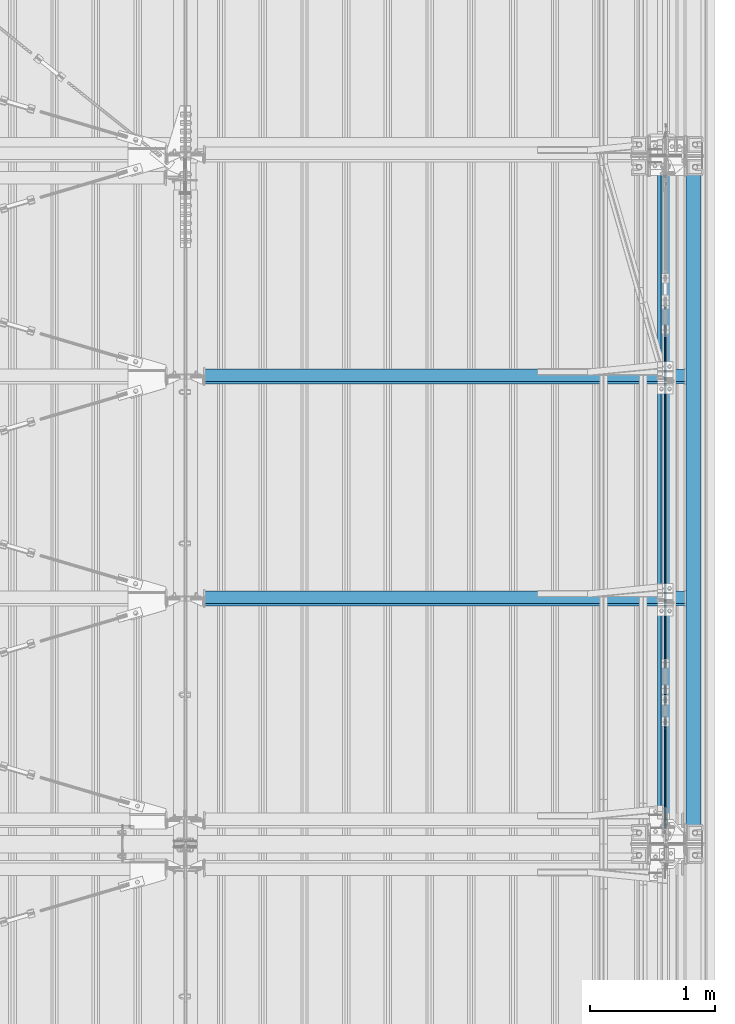
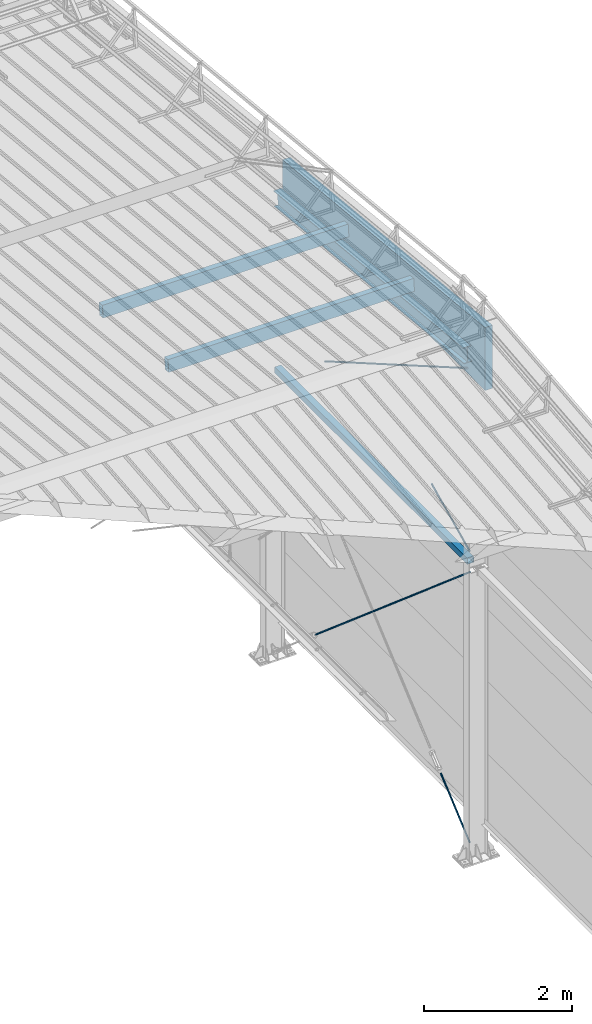
# One storey, part 283 of 709: 5 beams, 4 members, 4 openings, 9 elements without a shape of their own.
"""IFC4 building model written with IfcOpenShell, lengths in millimetres."""

from ifc_helpers import new_model, si_unit, direction, frame, origin_with_axes, place, context, subcontext, project, spatial, line, indexed_curve, outline, extrude, polygons, material, element, aggregate, save


model = new_model("IFC4")

# Units and contexts
model_context = context("Model", 3, precision=0.2, world=origin_with_axes(), true_north=direction((0.0, 1.0)))
body_context = subcontext(model_context, "Body", "Model", "MODEL_VIEW")
reference_context = subcontext(model_context, "Reference", "Model", "MODEL_VIEW")
ifc_project = project(units=[si_unit("LENGTHUNIT", "METRE", prefix="MILLI"), si_unit("AREAUNIT", "SQUARE_METRE"), si_unit("VOLUMEUNIT", "CUBIC_METRE"), si_unit("MASSUNIT", "GRAM", prefix="KILO"), si_unit("TIMEUNIT", "SECOND"), si_unit("PLANEANGLEUNIT", "RADIAN"), si_unit("SOLIDANGLEUNIT", "STERADIAN"), si_unit("THERMODYNAMICTEMPERATUREUNIT", "DEGREE_CELSIUS"), si_unit("LUMINOUSINTENSITYUNIT", "LUMEN")], contexts=[model_context])

# Site, building, storey
site_placement = place(None, origin_with_axes())
site = spatial("IfcSite", under=ifc_project, at=site_placement, CompositionType="ELEMENT")
building_placement = place(site_placement, origin_with_axes())
building = spatial("IfcBuilding", under=site, at=building_placement, Name="Undefined", CompositionType="ELEMENT")
storey_placement = place(building_placement, origin_with_axes())
storey = spatial("IfcBuildingStorey", under=building, at=storey_placement, Name="Undefined", CompositionType="ELEMENT", Elevation=0.0)

# Assembly, beam
assembly_1_placement = place(storey_placement, frame((49837.5, 16500.0, 7445.307), z_axis=(-1.0, 0.0, 0.0), x_axis=(0.0, -0.9950371902, 0.099503719)))
assembly_1 = element("IfcElementAssembly", 1, at=assembly_1_placement, inside=storey)
ifc_material_1 = material(Name="C255-4", Category="STEEL")
beam_1_placement = place(assembly_1_placement, origin_with_axes())
beam_1 = element("IfcBeam", 2, at=beam_1_placement, material=ifc_material_1, ObjectType="452", context=body_context, shape_type="Tessellation", body=[
    polygons([(166.87157, -124.0, 62.0), (166.87157, -116.0, 62.0), (166.87157, -116.0, 2.5), (166.87157, 116.0, 2.5), (166.87157, 116.0, 62.0), (166.87157, 124.0, 62.0), (166.87157, 124.0, -62.0), (166.87157, 116.0, -62.0), (166.87157, 116.0, -2.5), (166.87157, -116.0, -2.5), (166.87157, -116.0, -62.0), (166.87157, -124.0, -62.0), (5323.56002, 124.0, 62.0), (5323.56002, 124.0, -62.0), (5323.56002, 116.0, -62.0), (5323.56002, 116.0, -2.5), (5323.56002, -116.0, -2.5), (5323.56002, -116.0, -62.0), (5323.56002, -124.0, -62.0), (5323.56002, -124.0, 62.0), (5323.56002, -116.0, 62.0), (5323.56002, -116.0, 2.5), (5323.56002, 116.0, 2.5), (5323.56002, 116.0, 62.0)], [[[1, 2, 3, 4, 5, 6, 7, 8, 9, 10, 11, 12]], [[7, 6, 13, 14]], [[8, 7, 14, 15]], [[9, 8, 15, 16]], [[10, 9, 16, 17]], [[11, 10, 17, 18]], [[12, 11, 18, 19]], [[1, 12, 19, 20]], [[2, 1, 20, 21]], [[3, 2, 21, 22]], [[4, 3, 22, 23]], [[5, 4, 23, 24]], [[6, 5, 24, 13]], [[23, 22, 21, 20, 19, 18, 17, 16, 15, 14, 13, 24]]], closed=True),
])
aggregate(assembly_1, [beam_1])

assembly_2_placement = place(storey_placement, frame((49851.0, 11000.0, 4610.0), z_axis=(0.0, 0.0, -1.0), x_axis=(0.0, 1.0, 0.0)))
assembly_2 = element("IfcElementAssembly", 3, at=assembly_2_placement, inside=storey)
ifc_material_2 = material(Name="C355", Category="STEEL")
beam_2_placement = place(assembly_2_placement, origin_with_axes())
beam_2 = element("IfcBeam", 4, at=beam_2_placement, material=ifc_material_2, ObjectType="512", context=body_context, shape_type="Tessellation", body=[
    polygons([(142.5, -47.0, -47.0), (142.5, -47.0, 47.0), (5357.5, -47.0, 47.0), (5357.5, -47.0, -47.0), (142.5, 47.0, 47.0), (5357.5, 47.0, 47.0), (142.5, 47.0, -47.0), (5357.5, 47.0, -47.0), (142.5, -50.0, -50.0), (142.5, 50.0, -50.0), (5357.5, 50.0, -50.0), (5357.5, -50.0, -50.0), (142.5, 50.0, 50.0), (5357.5, 50.0, 50.0), (142.5, -50.0, 50.0), (5357.5, -50.0, 50.0)], [[[1, 2, 3, 4]], [[2, 5, 6, 3]], [[5, 7, 8, 6]], [[7, 1, 4, 8]], [[9, 10, 11, 12]], [[10, 13, 14, 11]], [[13, 15, 16, 14]], [[15, 9, 12, 16]], [[14, 16, 12, 11], [6, 8, 4, 3]], [[15, 13, 10, 9], [7, 5, 2, 1]]], closed=True),
])
aggregate(assembly_2, [beam_2])

# Assembly, member, voiding feature
assembly_3_placement = place(storey_placement, frame((49835.0, 11000.0, -155.0), z_axis=(1.0, 0.0, 0.0), x_axis=(0.0, 0.7603239329, 0.649544084)))
assembly_3 = element("IfcElementAssembly", 5, at=assembly_3_placement, inside=storey)
ifc_material_3 = material(Name="C355-5", Category="STEEL")
member_1_placement = place(assembly_3_placement, origin_with_axes())
member_1 = element("IfcMember", 6, at=member_1_placement, material=ifc_material_3, ObjectType="513", context=body_context, shape_type="Tessellation", body=[
    polygons([(1390.0, 7.36122, 4.25), (1390.0, 6.01041, 6.01041), (1390.0, 4.25, 7.36122), (1390.0, 2.19996, 8.21037), (1390.0, 0.0, 8.5), (1390.0, -2.19996, 8.21037), (1390.0, -4.25, 7.36122), (1390.0, -6.01041, 6.01041), (1390.0, -7.36122, 4.25), (1390.0, -8.21037, 2.19996), (1390.0, -8.5, 0.0), (1390.0, -8.21037, -2.19996), (1390.0, -7.36122, -4.25), (1390.0, -6.01041, -6.01041), (1390.0, -4.25, -7.36122), (1390.0, -2.19996, -8.21037), (1390.0, 0.0, -8.5), (1390.0, 2.19996, -8.21037), (1390.0, 4.25, -7.36122), (1390.0, 6.01041, -6.01041), (1390.0, 7.36122, -4.25), (1390.0, 8.21037, -2.19996), (1390.0, 8.5, 0.0), (1390.0, 8.21037, 2.19996), (1210.0, 8.21037, 2.19996), (1210.0, 7.36122, 4.25), (1210.0, 6.01041, 6.01041), (1210.0, 4.25, 7.36122), (1210.0, 2.19996, 8.21037), (1210.0, 0.0, 8.5), (1210.0, -2.19996, 8.21037), (1210.0, -4.25, 7.36122), (1210.0, -6.01041, 6.01041), (1210.0, -7.36122, 4.25), (1210.0, -8.21037, 2.19996), (1210.0, -8.5, 0.0), (1210.0, -8.21037, -2.19996), (1210.0, -7.36122, -4.25), (1210.0, -6.01041, -6.01041), (1210.0, -4.25, -7.36122), (1210.0, -2.19996, -8.21037), (1210.0, 0.0, -8.5), (1210.0, 2.19996, -8.21037), (1210.0, 4.25, -7.36122), (1210.0, 6.01041, -6.01041), (1210.0, 7.36122, -4.25), (1210.0, 8.21037, -2.19996), (1210.0, 8.5, 0.0), (1210.0, 10.0, 0.0), (1210.0, 9.65926, 2.58819), (1210.0, 8.66025, 5.0), (1210.0, 7.07107, 7.07107), (1210.0, 5.0, 8.66025), (1210.0, 2.58819, 9.65926), (1210.0, 0.0, 10.0), (1210.0, -2.58819, 9.65926), (1210.0, -5.0, 8.66025), (1210.0, -7.07107, 7.07107), (1210.0, -8.66025, 5.0), (1210.0, -9.65926, 2.58819), (1210.0, -10.0, 0.0), (1210.0, -9.65926, -2.58819), (1210.0, -8.66025, -5.0), (1210.0, -7.07107, -7.07107), (1210.0, -5.0, -8.66025), (1210.0, -2.58819, -9.65926), (1210.0, 0.0, -10.0), (1210.0, 2.58819, -9.65926), (1210.0, 5.0, -8.66025), (1210.0, 7.07107, -7.07107), (1210.0, 8.66025, -5.0), (1210.0, 9.65926, -2.58819), (179.82193, 2.58819, 9.65926), (179.82193, 5.0, 8.66025), (179.82193, 7.07107, 7.07107), (179.82193, 8.66025, 5.0), (179.82193, 9.65926, 2.58819), (179.82193, 10.0, 0.0), (179.82193, 9.65926, -2.58819), (179.82193, 8.66025, -5.0), (179.82193, 7.07107, -7.07107), (179.82193, 5.0, -8.66025), (179.82193, 2.58819, -9.65926), (179.82193, 0.0, -10.0), (179.82193, -2.58819, -9.65926), (179.82193, -5.0, -8.66025), (179.82193, -7.07107, -7.07107), (179.82193, -8.66025, -5.0), (179.82193, -9.65926, -2.58819), (179.82193, -10.0, 0.0), (179.82193, -9.65926, 2.58819), (179.82193, -8.66025, 5.0), (179.82193, -7.07107, 7.07107), (179.82193, -5.0, 8.66025), (179.82193, -2.58819, 9.65926), (179.82193, 0.0, 10.0)], [[[1, 2, 3, 4, 5, 6, 7, 8, 9, 10, 11, 12, 13, 14, 15, 16, 17, 18, 19, 20, 21, 22, 23, 24]], [[24, 25, 26, 1]], [[1, 26, 27, 2]], [[2, 27, 28, 3]], [[3, 28, 29, 4]], [[4, 29, 30, 5]], [[5, 30, 31, 6]], [[6, 31, 32, 7]], [[7, 32, 33, 8]], [[8, 33, 34, 9]], [[9, 34, 35, 10]], [[10, 35, 36, 11]], [[11, 36, 37, 12]], [[12, 37, 38, 13]], [[13, 38, 39, 14]], [[14, 39, 40, 15]], [[15, 40, 41, 16]], [[16, 41, 42, 17]], [[17, 42, 43, 18]], [[18, 43, 44, 19]], [[19, 44, 45, 20]], [[20, 45, 46, 21]], [[21, 46, 47, 22]], [[22, 47, 48, 23]], [[23, 48, 25, 24]], [[49, 50, 51, 52, 53, 54, 55, 56, 57, 58, 59, 60, 61, 62, 63, 64, 65, 66, 67, 68, 69, 70, 71, 72], [47, 46, 45, 44, 43, 42, 41, 40, 39, 38, 37, 36, 35, 34, 33, 32, 31, 30, 29, 28, 27, 26, 25, 48]], [[73, 74, 75, 76, 77, 78, 79, 80, 81, 82, 83, 84, 85, 86, 87, 88, 89, 90, 91, 92, 93, 94, 95, 96]], [[79, 78, 49, 72]], [[80, 79, 72, 71]], [[81, 80, 71, 70]], [[82, 81, 70, 69]], [[83, 82, 69, 68]], [[84, 83, 68, 67]], [[85, 84, 67, 66]], [[86, 85, 66, 65]], [[87, 86, 65, 64]], [[88, 87, 64, 63]], [[89, 88, 63, 62]], [[90, 89, 62, 61]], [[91, 90, 61, 60]], [[92, 91, 60, 59]], [[93, 92, 59, 58]], [[94, 93, 58, 57]], [[95, 94, 57, 56]], [[96, 95, 56, 55]], [[73, 96, 55, 54]], [[74, 73, 54, 53]], [[75, 74, 53, 52]], [[76, 75, 52, 51]], [[77, 76, 51, 50]], [[78, 77, 50, 49]]], closed=True),
])
voiding_feature_1_placement = place(member_1_placement, frame((1390.0, 0.0, 0.0), z_axis=(0.0, 1.0, 0.0), x_axis=(-1.0, 0.0, 0.0)))
element("IfcVoidingFeature", 7, at=voiding_feature_1_placement, cuts=member_1, PredefinedType="HOLE", context=reference_context, identifier="Reference", shape_type="SolidModel", body=[
    extrude(outline(indexed_curve([(10.5, 0.0), (10.14222, 2.7176), (9.09327, 5.25), (7.42462, 7.42462), (5.25, 9.09327), (2.7176, 10.14222), (0.0, 10.5), (-2.7176, 10.14222), (-5.25, 9.09327), (-7.42462, 7.42462), (-9.09327, 5.25), (-10.14222, 2.7176), (-10.5, 0.0), (-10.14222, -2.7176), (-9.09327, -5.25), (-7.42462, -7.42462), (-5.25, -9.09327), (-2.7176, -10.14222), (0.0, -10.5), (2.7176, -10.14222), (5.25, -9.09327), (7.42462, -7.42462), (9.09327, -5.25), (10.14222, -2.7176)], segments=[line(1, 2, 3, 4, 5, 6, 7, 8, 9, 10, 11, 12, 13, 14, 15, 16, 17, 18, 19, 20, 21, 22, 23, 24, 1)])), frame((0.0, 0.0, 0.0), z_axis=(-1.0, 0.0, 0.0), x_axis=(0.0, 0.0, 1.0)), (0.0, 0.0, -1.0), 180.0),
])
aggregate(assembly_3, [member_1])

assembly_4_placement = place(storey_placement, frame((49835.0, 11074.5, 4480.0), z_axis=(1.0, 0.0, 0.0), x_axis=(0.0, 0.7603239329, -0.649544084)))
assembly_4 = element("IfcElementAssembly", 8, at=assembly_4_placement, inside=storey)
member_2_placement = place(assembly_4_placement, origin_with_axes())
member_2 = element("IfcMember", 9, at=member_2_placement, material=ifc_material_3, ObjectType="514", context=body_context, shape_type="Tessellation", body=[
    polygons([(5725.77433, 7.36121, 4.25), (5725.77433, 6.01041, 6.01041), (5725.77433, 4.25, 7.36122), (5725.77433, 2.19996, 8.21037), (5725.77433, 0.0, 8.5), (5725.77433, -2.19996, 8.21037), (5725.77433, -4.25, 7.36122), (5725.77433, -6.01041, 6.01041), (5725.77433, -7.36122, 4.25), (5725.77433, -8.21037, 2.19996), (5725.77433, -8.5, 0.0), (5725.77433, -8.21037, -2.19996), (5725.77433, -7.36122, -4.25), (5725.77433, -6.01041, -6.01041), (5725.77433, -4.25, -7.36122), (5725.77433, -2.19996, -8.21037), (5725.77433, 0.0, -8.5), (5725.77433, 2.19996, -8.21037), (5725.77433, 4.25, -7.36122), (5725.77433, 6.01041, -6.01041), (5725.77433, 7.36121, -4.25), (5725.77433, 8.21037, -2.19996), (5725.77433, 8.5, 0.0), (5725.77433, 8.21037, 2.19996), (5545.77433, 8.21037, 2.19996), (5545.77433, 7.36121, 4.25), (5545.77433, 6.01041, 6.01041), (5545.77433, 4.25, 7.36122), (5545.77433, 2.19996, 8.21037), (5545.77433, 0.0, 8.5), (5545.77433, -2.19996, 8.21037), (5545.77433, -4.25, 7.36122), (5545.77433, -6.01041, 6.01041), (5545.77433, -7.36122, 4.25), (5545.77433, -8.21037, 2.19996), (5545.77433, -8.5, 0.0), (5545.77433, -8.21037, -2.19996), (5545.77433, -7.36122, -4.25), (5545.77433, -6.01041, -6.01041), (5545.77433, -4.25, -7.36122), (5545.77433, -2.19996, -8.21037), (5545.77433, 0.0, -8.5), (5545.77433, 2.19996, -8.21037), (5545.77433, 4.25, -7.36122), (5545.77433, 6.01041, -6.01041), (5545.77433, 7.36121, -4.25), (5545.77433, 8.21037, -2.19996), (5545.77433, 8.5, 0.0), (5545.77433, 10.0, 0.0), (5545.77433, 9.65926, 2.58819), (5545.77433, 8.66025, 5.0), (5545.77433, 7.07107, 7.07107), (5545.77433, 5.0, 8.66025), (5545.77433, 2.58819, 9.65926), (5545.77433, 0.0, 10.0), (5545.77433, -2.58819, 9.65926), (5545.77433, -5.0, 8.66025), (5545.77433, -7.07107, 7.07107), (5545.77433, -8.66025, 5.0), (5545.77433, -9.65926, 2.58819), (5545.77433, -10.0, 0.0), (5545.77433, -9.65926, -2.58819), (5545.77433, -8.66025, -5.0), (5545.77433, -7.07107, -7.07107), (5545.77433, -5.0, -8.66025), (5545.77433, -2.58819, -9.65926), (5545.77433, 0.0, -10.0), (5545.77433, 2.58819, -9.65926), (5545.77433, 5.0, -8.66025), (5545.77433, 7.07107, -7.07107), (5545.77433, 8.66025, -5.0), (5545.77433, 9.65926, -2.58819), (70.0, 2.58819, 9.65926), (70.0, 5.0, 8.66025), (70.0, 7.07107, 7.07107), (70.0, 8.66025, 5.0), (70.0, 9.65926, 2.58819), (70.0, 10.0, 0.0), (70.0, 9.65926, -2.58819), (70.0, 8.66025, -5.0), (70.0, 7.07107, -7.07107), (70.0, 5.0, -8.66025), (70.0, 2.58819, -9.65926), (70.0, 0.0, -10.0), (70.0, -2.58819, -9.65926), (70.0, -5.0, -8.66025), (70.0, -7.07107, -7.07107), (70.0, -8.66025, -5.0), (70.0, -9.65926, -2.58819), (70.0, -10.0, 0.0), (70.0, -9.65926, 2.58819), (70.0, -8.66025, 5.0), (70.0, -7.07107, 7.07107), (70.0, -5.0, 8.66025), (70.0, -2.58819, 9.65926), (70.0, 0.0, 10.0)], [[[1, 2, 3, 4, 5, 6, 7, 8, 9, 10, 11, 12, 13, 14, 15, 16, 17, 18, 19, 20, 21, 22, 23, 24]], [[24, 25, 26, 1]], [[1, 26, 27, 2]], [[2, 27, 28, 3]], [[3, 28, 29, 4]], [[4, 29, 30, 5]], [[5, 30, 31, 6]], [[6, 31, 32, 7]], [[7, 32, 33, 8]], [[8, 33, 34, 9]], [[9, 34, 35, 10]], [[10, 35, 36, 11]], [[11, 36, 37, 12]], [[12, 37, 38, 13]], [[13, 38, 39, 14]], [[14, 39, 40, 15]], [[15, 40, 41, 16]], [[16, 41, 42, 17]], [[17, 42, 43, 18]], [[18, 43, 44, 19]], [[19, 44, 45, 20]], [[20, 45, 46, 21]], [[21, 46, 47, 22]], [[22, 47, 48, 23]], [[23, 48, 25, 24]], [[49, 50, 51, 52, 53, 54, 55, 56, 57, 58, 59, 60, 61, 62, 63, 64, 65, 66, 67, 68, 69, 70, 71, 72], [47, 46, 45, 44, 43, 42, 41, 40, 39, 38, 37, 36, 35, 34, 33, 32, 31, 30, 29, 28, 27, 26, 25, 48]], [[73, 74, 75, 76, 77, 78, 79, 80, 81, 82, 83, 84, 85, 86, 87, 88, 89, 90, 91, 92, 93, 94, 95, 96]], [[79, 78, 49, 72]], [[80, 79, 72, 71]], [[81, 80, 71, 70]], [[82, 81, 70, 69]], [[83, 82, 69, 68]], [[84, 83, 68, 67]], [[85, 84, 67, 66]], [[86, 85, 66, 65]], [[87, 86, 65, 64]], [[88, 87, 64, 63]], [[89, 88, 63, 62]], [[90, 89, 62, 61]], [[91, 90, 61, 60]], [[92, 91, 60, 59]], [[93, 92, 59, 58]], [[94, 93, 58, 57]], [[95, 94, 57, 56]], [[96, 95, 56, 55]], [[73, 96, 55, 54]], [[74, 73, 54, 53]], [[75, 74, 53, 52]], [[76, 75, 52, 51]], [[77, 76, 51, 50]], [[78, 77, 50, 49]]], closed=True),
])
voiding_feature_2_placement = place(member_2_placement, frame((5725.77433, 0.0, 0.0), z_axis=(0.0, 1.0, 0.0), x_axis=(-1.0, 0.0, 0.0)))
element("IfcVoidingFeature", 10, at=voiding_feature_2_placement, cuts=member_2, PredefinedType="HOLE", context=reference_context, identifier="Reference", shape_type="SolidModel", body=[
    extrude(outline(indexed_curve([(10.5, 0.0), (10.14222, 2.7176), (9.09327, 5.25), (7.42462, 7.42462), (5.25, 9.09327), (2.7176, 10.14222), (0.0, 10.5), (-2.7176, 10.14222), (-5.25, 9.09327), (-7.42462, 7.42462), (-9.09327, 5.25), (-10.14222, 2.7176), (-10.5, 0.0), (-10.14222, -2.7176), (-9.09327, -5.25), (-7.42462, -7.42462), (-5.25, -9.09327), (-2.7176, -10.14222), (0.0, -10.5), (2.7176, -10.14222), (5.25, -9.09327), (7.42462, -7.42462), (9.09327, -5.25), (10.14222, -2.7176)], segments=[line(1, 2, 3, 4, 5, 6, 7, 8, 9, 10, 11, 12, 13, 14, 15, 16, 17, 18, 19, 20, 21, 22, 23, 24, 1)])), frame((0.0, 0.0, 0.0), z_axis=(-1.0, 0.0, 0.0), x_axis=(0.0, 0.0, 1.0)), (0.0, 0.0, -1.0), 180.0),
])
aggregate(assembly_4, [member_2])

assembly_5_placement = place(storey_placement, frame((49835.0, 11074.5, 4740.0), z_axis=(1.0, 0.0, 0.0), x_axis=(0.0, 0.9030466941, 0.429542394)))
assembly_5 = element("IfcElementAssembly", 11, at=assembly_5_placement, inside=storey)
member_3_placement = place(assembly_5_placement, origin_with_axes())
member_3 = element("IfcMember", 12, at=member_3_placement, material=ifc_material_3, ObjectType="515", context=body_context, shape_type="Tessellation", body=[
    polygons([(1390.0, 7.36122, 4.25), (1390.0, 6.01041, 6.01041), (1390.0, 4.25, 7.36122), (1390.0, 2.19996, 8.21037), (1390.0, 0.0, 8.5), (1390.0, -2.19996, 8.21037), (1390.0, -4.25, 7.36122), (1390.0, -6.01041, 6.01041), (1390.0, -7.36122, 4.25), (1390.0, -8.21037, 2.19996), (1390.0, -8.5, 0.0), (1390.0, -8.21037, -2.19996), (1390.0, -7.36122, -4.25), (1390.0, -6.01041, -6.01041), (1390.0, -4.25, -7.36122), (1390.0, -2.19996, -8.21037), (1390.0, 0.0, -8.5), (1390.0, 2.19996, -8.21037), (1390.0, 4.25, -7.36122), (1390.0, 6.01041, -6.01041), (1390.0, 7.36122, -4.25), (1390.0, 8.21037, -2.19996), (1390.0, 8.5, 0.0), (1390.0, 8.21037, 2.19996), (1210.0, 8.21037, 2.19996), (1210.0, 7.36122, 4.25), (1210.0, 6.01041, 6.01041), (1210.0, 4.25, 7.36122), (1210.0, 2.19996, 8.21037), (1210.0, 0.0, 8.5), (1210.0, -2.19996, 8.21037), (1210.0, -4.25, 7.36122), (1210.0, -6.01041, 6.01041), (1210.0, -7.36122, 4.25), (1210.0, -8.21037, 2.19996), (1210.0, -8.5, 0.0), (1210.0, -8.21037, -2.19996), (1210.0, -7.36122, -4.25), (1210.0, -6.01041, -6.01041), (1210.0, -4.25, -7.36122), (1210.0, -2.19996, -8.21037), (1210.0, 0.0, -8.5), (1210.0, 2.19996, -8.21037), (1210.0, 4.25, -7.36122), (1210.0, 6.01041, -6.01041), (1210.0, 7.36122, -4.25), (1210.0, 8.21037, -2.19996), (1210.0, 8.5, 0.0), (1210.0, 10.0, 0.0), (1210.0, 9.65926, 2.58819), (1210.0, 8.66025, 5.0), (1210.0, 7.07107, 7.07107), (1210.0, 5.0, 8.66025), (1210.0, 2.58819, 9.65926), (1210.0, 0.0, 10.0), (1210.0, -2.58819, 9.65926), (1210.0, -5.0, 8.66025), (1210.0, -7.07107, 7.07107), (1210.0, -8.66025, 5.0), (1210.0, -9.65926, 2.58819), (1210.0, -10.0, 0.0), (1210.0, -9.65926, -2.58819), (1210.0, -8.66025, -5.0), (1210.0, -7.07107, -7.07107), (1210.0, -5.0, -8.66025), (1210.0, -2.58819, -9.65926), (1210.0, 0.0, -10.0), (1210.0, 2.58819, -9.65926), (1210.0, 5.0, -8.66025), (1210.0, 7.07107, -7.07107), (1210.0, 8.66025, -5.0), (1210.0, 9.65926, -2.58819), (70.0, 2.58819, 9.65926), (70.0, 5.0, 8.66025), (70.0, 7.07107, 7.07107), (70.0, 8.66025, 5.0), (70.0, 9.65926, 2.58819), (70.0, 10.0, 0.0), (70.0, 9.65926, -2.58819), (70.0, 8.66025, -5.0), (70.0, 7.07107, -7.07107), (70.0, 5.0, -8.66025), (70.0, 2.58819, -9.65926), (70.0, 0.0, -10.0), (70.0, -2.58819, -9.65926), (70.0, -5.0, -8.66025), (70.0, -7.07107, -7.07107), (70.0, -8.66025, -5.0), (70.0, -9.65926, -2.58819), (70.0, -10.0, 0.0), (70.0, -9.65926, 2.58819), (70.0, -8.66025, 5.0), (70.0, -7.07107, 7.07107), (70.0, -5.0, 8.66025), (70.0, -2.58819, 9.65926), (70.0, 0.0, 10.0)], [[[1, 2, 3, 4, 5, 6, 7, 8, 9, 10, 11, 12, 13, 14, 15, 16, 17, 18, 19, 20, 21, 22, 23, 24]], [[24, 25, 26, 1]], [[1, 26, 27, 2]], [[2, 27, 28, 3]], [[3, 28, 29, 4]], [[4, 29, 30, 5]], [[5, 30, 31, 6]], [[6, 31, 32, 7]], [[7, 32, 33, 8]], [[8, 33, 34, 9]], [[9, 34, 35, 10]], [[10, 35, 36, 11]], [[11, 36, 37, 12]], [[12, 37, 38, 13]], [[13, 38, 39, 14]], [[14, 39, 40, 15]], [[15, 40, 41, 16]], [[16, 41, 42, 17]], [[17, 42, 43, 18]], [[18, 43, 44, 19]], [[19, 44, 45, 20]], [[20, 45, 46, 21]], [[21, 46, 47, 22]], [[22, 47, 48, 23]], [[23, 48, 25, 24]], [[49, 50, 51, 52, 53, 54, 55, 56, 57, 58, 59, 60, 61, 62, 63, 64, 65, 66, 67, 68, 69, 70, 71, 72], [47, 46, 45, 44, 43, 42, 41, 40, 39, 38, 37, 36, 35, 34, 33, 32, 31, 30, 29, 28, 27, 26, 25, 48]], [[73, 74, 75, 76, 77, 78, 79, 80, 81, 82, 83, 84, 85, 86, 87, 88, 89, 90, 91, 92, 93, 94, 95, 96]], [[79, 78, 49, 72]], [[80, 79, 72, 71]], [[81, 80, 71, 70]], [[82, 81, 70, 69]], [[83, 82, 69, 68]], [[84, 83, 68, 67]], [[85, 84, 67, 66]], [[86, 85, 66, 65]], [[87, 86, 65, 64]], [[88, 87, 64, 63]], [[89, 88, 63, 62]], [[90, 89, 62, 61]], [[91, 90, 61, 60]], [[92, 91, 60, 59]], [[93, 92, 59, 58]], [[94, 93, 58, 57]], [[95, 94, 57, 56]], [[96, 95, 56, 55]], [[73, 96, 55, 54]], [[74, 73, 54, 53]], [[75, 74, 53, 52]], [[76, 75, 52, 51]], [[77, 76, 51, 50]], [[78, 77, 50, 49]]], closed=True),
])
voiding_feature_3_placement = place(member_3_placement, frame((1390.0, 0.0, 0.0), z_axis=(0.0, 1.0, 0.0), x_axis=(-1.0, 0.0, 0.0)))
element("IfcVoidingFeature", 13, at=voiding_feature_3_placement, cuts=member_3, PredefinedType="HOLE", context=reference_context, identifier="Reference", shape_type="SolidModel", body=[
    extrude(outline(indexed_curve([(10.5, 0.0), (10.14222, 2.7176), (9.09327, 5.25), (7.42462, 7.42462), (5.25, 9.09327), (2.7176, 10.14222), (0.0, 10.5), (-2.7176, 10.14222), (-5.25, 9.09327), (-7.42462, 7.42462), (-9.09327, 5.25), (-10.14222, 2.7176), (-10.5, 0.0), (-10.14222, -2.7176), (-9.09327, -5.25), (-7.42462, -7.42462), (-5.25, -9.09327), (-2.7176, -10.14222), (0.0, -10.5), (2.7176, -10.14222), (5.25, -9.09327), (7.42462, -7.42462), (9.09327, -5.25), (10.14222, -2.7176)], segments=[line(1, 2, 3, 4, 5, 6, 7, 8, 9, 10, 11, 12, 13, 14, 15, 16, 17, 18, 19, 20, 21, 22, 23, 24, 1)])), frame((0.0, 0.0, 0.0), z_axis=(-1.0, 0.0, 0.0), x_axis=(0.0, 0.0, 1.0)), (0.0, 0.0, -1.0), 180.0),
])
aggregate(assembly_5, [member_3])

assembly_6_placement = place(storey_placement, frame((49835.0, 11000.0, 7870.68854), z_axis=(1.0, 0.0, 0.0), x_axis=(0.0, 0.866144648, -0.499793406)))
assembly_6 = element("IfcElementAssembly", 14, at=assembly_6_placement, inside=storey)
member_4_placement = place(assembly_6_placement, origin_with_axes())
member_4 = element("IfcMember", 15, at=member_4_placement, material=ifc_material_3, ObjectType="516", context=body_context, shape_type="Tessellation", body=[
    polygons([(4853.96528, 7.36121, 4.25), (4853.96528, 6.01041, 6.01041), (4853.96528, 4.25, 7.36122), (4853.96528, 2.19996, 8.21037), (4853.96528, 0.0, 8.5), (4853.96528, -2.19996, 8.21037), (4853.96528, -4.25, 7.36122), (4853.96528, -6.01041, 6.01041), (4853.96528, -7.36122, 4.25), (4853.96528, -8.21037, 2.19996), (4853.96528, -8.5, 0.0), (4853.96528, -8.21037, -2.19996), (4853.96528, -7.36122, -4.25), (4853.96528, -6.01041, -6.01041), (4853.96528, -4.25, -7.36122), (4853.96528, -2.19996, -8.21037), (4853.96528, 0.0, -8.5), (4853.96528, 2.19996, -8.21037), (4853.96528, 4.25, -7.36122), (4853.96528, 6.01041, -6.01041), (4853.96528, 7.36121, -4.25), (4853.96528, 8.21037, -2.19996), (4853.96528, 8.5, 0.0), (4853.96528, 8.21037, 2.19996), (4673.96528, 8.21037, 2.19996), (4673.96528, 7.36121, 4.25), (4673.96528, 6.01041, 6.01041), (4673.96528, 4.25, 7.36122), (4673.96528, 2.19996, 8.21037), (4673.96528, 0.0, 8.5), (4673.96528, -2.19996, 8.21037), (4673.96528, -4.25, 7.36122), (4673.96528, -6.01041, 6.01041), (4673.96528, -7.36122, 4.25), (4673.96528, -8.21037, 2.19996), (4673.96528, -8.5, 0.0), (4673.96528, -8.21037, -2.19996), (4673.96528, -7.36122, -4.25), (4673.96528, -6.01041, -6.01041), (4673.96528, -4.25, -7.36122), (4673.96528, -2.19996, -8.21037), (4673.96528, 0.0, -8.5), (4673.96528, 2.19996, -8.21037), (4673.96528, 4.25, -7.36122), (4673.96528, 6.01041, -6.01041), (4673.96528, 7.36121, -4.25), (4673.96528, 8.21037, -2.19996), (4673.96528, 8.5, 0.0), (4673.96528, 10.0, 0.0), (4673.96528, 9.65926, 2.58819), (4673.96528, 8.66025, 5.0), (4673.96528, 7.07107, 7.07107), (4673.96528, 5.0, 8.66025), (4673.96528, 2.58819, 9.65926), (4673.96528, 0.0, 10.0), (4673.96528, -2.58819, 9.65926), (4673.96528, -5.0, 8.66025), (4673.96528, -7.07107, 7.07107), (4673.96528, -8.66025, 5.0), (4673.96528, -9.65926, 2.58819), (4673.96528, -10.0, 0.0), (4673.96528, -9.65926, -2.58819), (4673.96528, -8.66025, -5.0), (4673.96528, -7.07107, -7.07107), (4673.96528, -5.0, -8.66025), (4673.96528, -2.58819, -9.65926), (4673.96528, 0.0, -10.0), (4673.96528, 2.58819, -9.65926), (4673.96528, 5.0, -8.66025), (4673.96528, 7.07107, -7.07107), (4673.96528, 8.66025, -5.0), (4673.96528, 9.65926, -2.58819), (240.08921, 2.58819, 9.65926), (240.08921, 5.0, 8.66025), (240.08921, 7.07107, 7.07107), (240.08921, 8.66025, 5.0), (240.08921, 9.65926, 2.58819), (240.08921, 10.0, 0.0), (240.08921, 9.65926, -2.58819), (240.08921, 8.66025, -5.0), (240.08921, 7.07107, -7.07107), (240.08921, 5.0, -8.66025), (240.08921, 2.58819, -9.65926), (240.08921, 0.0, -10.0), (240.08921, -2.58819, -9.65926), (240.08921, -5.0, -8.66025), (240.08921, -7.07107, -7.07107), (240.08921, -8.66025, -5.0), (240.08921, -9.65926, -2.58819), (240.08921, -10.0, 0.0), (240.08921, -9.65926, 2.58819), (240.08921, -8.66025, 5.0), (240.08921, -7.07107, 7.07107), (240.08921, -5.0, 8.66025), (240.08921, -2.58819, 9.65926), (240.08921, 0.0, 10.0)], [[[1, 2, 3, 4, 5, 6, 7, 8, 9, 10, 11, 12, 13, 14, 15, 16, 17, 18, 19, 20, 21, 22, 23, 24]], [[24, 25, 26, 1]], [[1, 26, 27, 2]], [[2, 27, 28, 3]], [[3, 28, 29, 4]], [[4, 29, 30, 5]], [[5, 30, 31, 6]], [[6, 31, 32, 7]], [[7, 32, 33, 8]], [[8, 33, 34, 9]], [[9, 34, 35, 10]], [[10, 35, 36, 11]], [[11, 36, 37, 12]], [[12, 37, 38, 13]], [[13, 38, 39, 14]], [[14, 39, 40, 15]], [[15, 40, 41, 16]], [[16, 41, 42, 17]], [[17, 42, 43, 18]], [[18, 43, 44, 19]], [[19, 44, 45, 20]], [[20, 45, 46, 21]], [[21, 46, 47, 22]], [[22, 47, 48, 23]], [[23, 48, 25, 24]], [[49, 50, 51, 52, 53, 54, 55, 56, 57, 58, 59, 60, 61, 62, 63, 64, 65, 66, 67, 68, 69, 70, 71, 72], [47, 46, 45, 44, 43, 42, 41, 40, 39, 38, 37, 36, 35, 34, 33, 32, 31, 30, 29, 28, 27, 26, 25, 48]], [[73, 74, 75, 76, 77, 78, 79, 80, 81, 82, 83, 84, 85, 86, 87, 88, 89, 90, 91, 92, 93, 94, 95, 96]], [[79, 78, 49, 72]], [[80, 79, 72, 71]], [[81, 80, 71, 70]], [[82, 81, 70, 69]], [[83, 82, 69, 68]], [[84, 83, 68, 67]], [[85, 84, 67, 66]], [[86, 85, 66, 65]], [[87, 86, 65, 64]], [[88, 87, 64, 63]], [[89, 88, 63, 62]], [[90, 89, 62, 61]], [[91, 90, 61, 60]], [[92, 91, 60, 59]], [[93, 92, 59, 58]], [[94, 93, 58, 57]], [[95, 94, 57, 56]], [[96, 95, 56, 55]], [[73, 96, 55, 54]], [[74, 73, 54, 53]], [[75, 74, 53, 52]], [[76, 75, 52, 51]], [[77, 76, 51, 50]], [[78, 77, 50, 49]]], closed=True),
])
voiding_feature_4_placement = place(member_4_placement, frame((4853.96528, 0.0, 0.0), z_axis=(0.0, 1.0, 0.0), x_axis=(-1.0, 0.0, 0.0)))
element("IfcVoidingFeature", 16, at=voiding_feature_4_placement, cuts=member_4, PredefinedType="HOLE", context=reference_context, identifier="Reference", shape_type="SolidModel", body=[
    extrude(outline(indexed_curve([(10.5, 0.0), (10.14222, 2.7176), (9.09327, 5.25), (7.42462, 7.42462), (5.25, 9.09327), (2.7176, 10.14222), (0.0, 10.5), (-2.7176, 10.14222), (-5.25, 9.09327), (-7.42462, 7.42462), (-9.09327, 5.25), (-10.14222, 2.7176), (-10.5, 0.0), (-10.14222, -2.7176), (-9.09327, -5.25), (-7.42462, -7.42462), (-5.25, -9.09327), (-2.7176, -10.14222), (0.0, -10.5), (2.7176, -10.14222), (5.25, -9.09327), (7.42462, -7.42462), (9.09327, -5.25), (10.14222, -2.7176)], segments=[line(1, 2, 3, 4, 5, 6, 7, 8, 9, 10, 11, 12, 13, 14, 15, 16, 17, 18, 19, 20, 21, 22, 23, 24, 1)])), frame((0.0, 0.0, 0.0), z_axis=(-1.0, 0.0, 0.0), x_axis=(0.0, 0.0, 1.0)), (0.0, 0.0, -1.0), 180.0),
])
aggregate(assembly_6, [member_4])

# Assembly, beam
assembly_7_placement = place(storey_placement, frame((50000.0, 12963.34988, 8032.12913), z_axis=(0.0, -0.9950371902, 0.099503719), x_axis=(-1.0, 0.0, 0.0)))
assembly_7 = element("IfcElementAssembly", 17, at=assembly_7_placement, inside=storey)
beam_3_placement = place(assembly_7_placement, origin_with_axes())
beam_3 = element("IfcBeam", 18, at=beam_3_placement, material=ifc_material_2, ObjectType="563", context=body_context, shape_type="Tessellation", body=[
    polygons([(3845.0, 100.0, 50.0), (3845.0, 100.0, -50.0), (8.0, 100.0, -50.0), (8.0, 100.0, 50.0), (3845.0, -100.0, 50.0), (8.0, -100.0, 50.0), (3845.0, -100.0, -50.0), (8.0, -100.0, -50.0), (3845.0, 96.0, -46.0), (3845.0, 96.0, 46.0), (8.0, 96.0, 46.0), (8.0, 96.0, -46.0), (3845.0, -96.0, -46.0), (8.0, -96.0, -46.0), (3845.0, -96.0, 46.0), (8.0, -96.0, 46.0)], [[[1, 2, 3, 4]], [[5, 1, 4, 6]], [[7, 5, 6, 8]], [[2, 7, 8, 3]], [[1, 5, 7, 2], [10, 9, 13, 15]], [[9, 10, 11, 12]], [[13, 9, 12, 14]], [[15, 13, 14, 16]], [[10, 15, 16, 11]], [[8, 6, 4, 3], [14, 12, 11, 16]]], closed=True),
])
aggregate(assembly_7, [beam_3])

assembly_8_placement = place(storey_placement, frame((50000.0, 14736.65012, 7854.7991), z_axis=(0.0, -0.9950371902, 0.099503719), x_axis=(-1.0, 0.0, 0.0)))
assembly_8 = element("IfcElementAssembly", 19, at=assembly_8_placement, inside=storey)
beam_4_placement = place(assembly_8_placement, origin_with_axes())
beam_4 = element("IfcBeam", 20, at=beam_4_placement, material=ifc_material_2, ObjectType="563", context=body_context, shape_type="Tessellation", body=[
    polygons([(3845.0, 100.0, 50.0), (3845.0, 100.0, -50.0), (8.0, 100.0, -50.0), (8.0, 100.0, 50.0), (3845.0, -100.0, 50.0), (8.0, -100.0, 50.0), (3845.0, -100.0, -50.0), (8.0, -100.0, -50.0), (3845.0, 96.0, -46.0), (3845.0, 96.0, 46.0), (8.0, 96.0, 46.0), (8.0, 96.0, -46.0), (3845.0, -96.0, -46.0), (8.0, -96.0, -46.0), (3845.0, -96.0, 46.0), (8.0, -96.0, 46.0)], [[[1, 2, 3, 4]], [[5, 1, 4, 6]], [[7, 5, 6, 8]], [[2, 7, 8, 3]], [[1, 5, 7, 2], [10, 9, 13, 15]], [[9, 10, 11, 12]], [[13, 9, 12, 14]], [[15, 13, 14, 16]], [[10, 15, 16, 11]], [[8, 6, 4, 3], [14, 12, 11, 16]]], closed=True),
])
aggregate(assembly_8, [beam_4])

assembly_9_placement = place(storey_placement, frame((50060.0, 11010.0, 8035.0), z_axis=(0.0, 0.0, -1.0), x_axis=(0.0, 1.0, 0.0)))
assembly_9 = element("IfcElementAssembly", 21, at=assembly_9_placement, inside=storey)
ifc_material_4 = material(Name="Insulation", Category="Insulation")
beam_5_placement = place(assembly_9_placement, origin_with_axes())
beam_5 = element("IfcBeam", 22, at=beam_5_placement, material=ifc_material_4, ObjectType="P-136", context=body_context, shape_type="Tessellation", body=[
    polygons([(0.0, 60.0, 595.0), (0.0, -60.0, 595.0), (5480.0, -60.0, 595.0), (5480.0, 60.0, 595.0), (5480.0, 60.0, 104.329), (0.0, 60.0, -443.671), (0.0, -60.0, -443.671), (5480.0, -60.0, 104.329)], [[[1, 2, 3, 4]], [[1, 4, 5, 6]], [[2, 1, 6, 7]], [[3, 2, 7, 8]], [[4, 3, 8, 5]], [[7, 6, 5, 8]]], closed=True),
])
aggregate(assembly_9, [beam_5])

save(model, "model.ifc")
